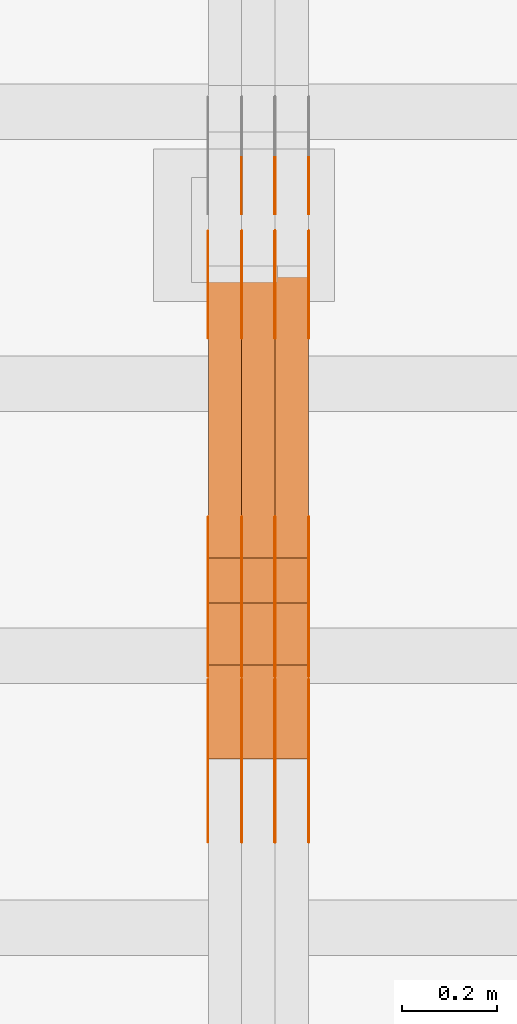
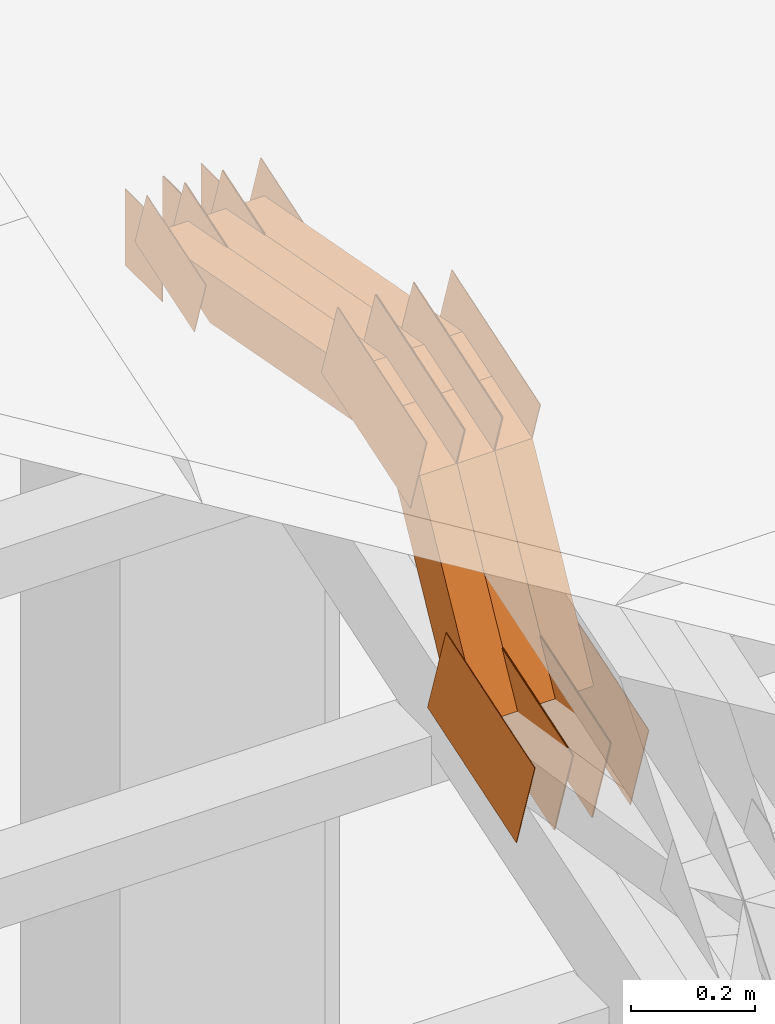
# One storey, part 277 of 385: 28 proxies.
"""IFC2X3 building model written with IfcOpenShell, lengths in millimetres."""

import ifcopenshell
import ifcopenshell.guid

model = None  # the IFC model being written
_history = None  # IfcOwnerHistory: only IFC2X3 demands one
_inside = {}  # id of a spatial element -> (the spatial element, [elements in it])
_under = {}  # id of a project, library or spatial element -> (it, [spatial elements below it])
_declared = {}  # id of a project -> (the project, [libraries it declares])
_typed = {}  # id of a type object -> (the type object, [elements of that type])
_made_of = {}  # id of a material, layer set ... -> (it, [elements and type objects made of it])


def new_model(schema):
    """Start an empty IFC model of exactly this schema.

    Asked for "IFC4X3", IfcOpenShell would pick the latest addendum, in which some entities
    have other attributes; the version numbers below select the first issue.
    IFC2X3 requires an IfcOwnerHistory on every rooted entity: one is made here for all.
    """
    global model, _history
    if schema == "IFC4X3":
        model = ifcopenshell.file(schema_version=(4, 3, 0, 0))
    else:
        model = ifcopenshell.file(schema=schema)
    _inside.clear()
    _under.clear()
    _declared.clear()
    _typed.clear()
    _made_of.clear()
    _history = None
    if model.schema == "IFC2X3":
        org = make("IfcOrganization", Name="unknown")
        user = make(
            "IfcPersonAndOrganization",
            ThePerson=make("IfcPerson", FamilyName="unknown"),
            TheOrganization=org,
        )
        app = make(
            "IfcApplication",
            ApplicationDeveloper=org,
            Version="unknown",
            ApplicationFullName="unknown",
            ApplicationIdentifier="unknown",
        )
        _history = make(
            "IfcOwnerHistory",
            OwningUser=user,
            OwningApplication=app,
            ChangeAction="ADDED",
            CreationDate=0,
        )
    return model


def make(cls, **values):
    """One entity of the class cls with the attributes given. An attribute that is None is left unset."""
    return model.create_entity(
        cls, **{name: value for name, value in values.items() if value is not None}
    )


def entity(cls, *values):
    """Any entity or typed value of the class cls, its attributes in the order of the schema. None: left unset."""
    e = model.create_entity(cls)
    for i, value in enumerate(values):
        if value is not None:
            e[i] = value
    return e


def rooted(cls, **values):
    """An entity with a GlobalId (a new one), such as an element, a storey or a relation."""
    return make(cls, GlobalId=ifcopenshell.guid.new(), OwnerHistory=_history, **values)


def si_unit(unit_type, name, prefix=None):
    """IfcSIUnit, for example si_unit("LENGTHUNIT", "METRE", prefix="MILLI")."""
    return make("IfcSIUnit", UnitType=unit_type, Prefix=prefix, Name=name)


def converted_unit(unit_type, name, factor, base, dimensions=None, offset=None):
    """IfcConversionBasedUnit, such as the inch: factor (a typed value) times the base unit."""
    return make(
        "IfcConversionBasedUnit"
        if offset is None
        else "IfcConversionBasedUnitWithOffset",
        ConversionOffset=offset,
        Dimensions=None
        if dimensions is None
        else entity("IfcDimensionalExponents", *dimensions),
        UnitType=unit_type,
        Name=name,
        ConversionFactor=make(
            "IfcMeasureWithUnit", ValueComponent=factor, UnitComponent=base
        ),
    )


def derived_unit(unit_type, elements):
    """IfcDerivedUnit: a product of units, each with its exponent."""
    return make(
        "IfcDerivedUnit",
        Elements=[
            make("IfcDerivedUnitElement", Unit=unit, Exponent=power)
            for unit, power in elements
        ],
        UnitType=unit_type,
    )


def assignment(units):
    """IfcUnitAssignment: the units of a project."""
    return None if units is None else make("IfcUnitAssignment", Units=units)


def point(xyz):
    """IfcCartesianPoint."""
    return None if xyz is None else make("IfcCartesianPoint", Coordinates=xyz)


def direction(xyz):
    """IfcDirection."""
    return None if xyz is None else make("IfcDirection", DirectionRatios=xyz)


def frame(location, z_axis=None, x_axis=None):
    """IfcAxis2Placement3D, a coordinate frame: its origin and axes. An axis left out is left unset."""
    return make(
        "IfcAxis2Placement3D",
        Location=point(location),
        Axis=direction(z_axis),
        RefDirection=direction(x_axis),
    )


def frame_2d(location, x_axis=None):
    """IfcAxis2Placement2D, a coordinate frame in the plane: its origin and x axis."""
    return make(
        "IfcAxis2Placement2D", Location=point(location), RefDirection=direction(x_axis)
    )


def origin():
    """The frame at (0, 0, 0) with its axes left unset."""
    return frame((0.0, 0.0, 0.0))


def place(relative_to, where):
    """IfcLocalPlacement: puts the frame where relative to a parent placement (None: the world)."""
    return make(
        "IfcLocalPlacement", PlacementRelTo=relative_to, RelativePlacement=where
    )


def context(
    kind, dimensions, precision=None, world=None, true_north=None, identifier=None
):
    """IfcGeometricRepresentationContext, for example the 3D "Model" context."""
    return make(
        "IfcGeometricRepresentationContext",
        ContextIdentifier=identifier,
        ContextType=kind,
        CoordinateSpaceDimension=dimensions,
        Precision=precision,
        WorldCoordinateSystem=world,
        TrueNorth=true_north,
    )


def subcontext(parent, identifier, kind, view, scale=None):
    """IfcGeometricRepresentationSubContext, for example "Body" below "Model"."""
    return make(
        "IfcGeometricRepresentationSubContext",
        ContextIdentifier=identifier,
        ContextType=kind,
        ParentContext=parent,
        TargetScale=scale,
        TargetView=view,
    )


def project(units=None, contexts=None):
    """IfcProject with its units and contexts."""
    return rooted(
        "IfcProject",
        Name="project",
        RepresentationContexts=contexts,
        UnitsInContext=assignment(units),
    )


def spatial(cls, under=None, at=None, **own):
    """A site, building, storey or space (cls), placed at a placement, below another one or the project."""
    s = rooted(cls, ObjectPlacement=at, **own)
    if under is not None:
        _under.setdefault(under.id(), (under, []))[1].append(s)
    return s


def polyline(points):
    """IfcPolyline through the points."""
    return make("IfcPolyline", Points=[point(p) for p in points])


def profile(cls, at=None, kind="AREA", **sizes):
    """A parametric profile (cls). Its sizes go by their IFC names, for example OverallWidth=200.0."""
    return make(cls, ProfileType=kind, Position=at, **sizes)


def rectangle(**sizes):
    """IfcRectangleProfileDef."""
    return profile("IfcRectangleProfileDef", **sizes)


def outline(outer, holes=None, kind="AREA"):
    """IfcArbitraryClosedProfileDef: a profile drawn as a closed curve; with holes, ...WithVoids."""
    if holes is None:
        return make("IfcArbitraryClosedProfileDef", ProfileType=kind, OuterCurve=outer)
    return make(
        "IfcArbitraryProfileDefWithVoids",
        ProfileType=kind,
        OuterCurve=outer,
        InnerCurves=holes,
    )


def extrude(swept, where, along, depth):
    """IfcExtrudedAreaSolid: the profile swept, set in the frame where, extruded along a direction by depth."""
    return make(
        "IfcExtrudedAreaSolid",
        SweptArea=swept,
        Position=where,
        ExtrudedDirection=direction(along),
        Depth=depth,
    )


def shape(context_of_items, identifier, shape_type, items):
    """IfcShapeRepresentation: the items that make up one representation, for example the "Body"."""
    return make(
        "IfcShapeRepresentation",
        ContextOfItems=context_of_items,
        RepresentationIdentifier=identifier,
        RepresentationType=shape_type,
        Items=items,
    )


def source(mapping_origin, context_of_items, identifier, shape_type, items):
    """IfcRepresentationMap: a shape defined once, which mapped items show again and again."""
    return make(
        "IfcRepresentationMap",
        MappingOrigin=mapping_origin,
        MappedRepresentation=shape(context_of_items, identifier, shape_type, items),
    )


def transform(
    local_origin,
    x_axis=None,
    y_axis=None,
    z_axis=None,
    scale=None,
    scale2=None,
    scale3=None,
    uniform=True,
):
    """IfcCartesianTransformationOperator3D, or its non-uniform kind. x_axis, y_axis, z_axis: its Axis1, 2, 3."""
    if uniform:
        return make(
            "IfcCartesianTransformationOperator3D",
            Axis1=direction(x_axis),
            Axis2=direction(y_axis),
            LocalOrigin=point(local_origin),
            Scale=scale,
            Axis3=direction(z_axis),
        )
    return make(
        "IfcCartesianTransformationOperator3DnonUniform",
        Axis1=direction(x_axis),
        Axis2=direction(y_axis),
        LocalOrigin=point(local_origin),
        Scale=scale,
        Axis3=direction(z_axis),
        Scale2=scale2,
        Scale3=scale3,
    )


def mapped(mapping_source, mapping_target):
    """IfcMappedItem: shows the shape of a source again, moved by a transform."""
    return make(
        "IfcMappedItem", MappingSource=mapping_source, MappingTarget=mapping_target
    )


def material(Name=None, Category=None):
    """IfcMaterial."""
    return make("IfcMaterial", Name=Name, Category=Category)


def made_of(thing, what):
    """Note that an element or type object is made of a material, layer set ...; save() writes the relation."""
    if what is not None:
        _made_of.setdefault(what.id(), (what, []))[1].append(thing)
    return thing


def type_object(cls, material=None, **own):
    """A type object (cls), such as IfcWallType, which elements share."""
    return made_of(rooted(cls, **own), material)


def type_shapes(of_type, sources):
    """Give a type object the sources (RepresentationMaps) that its elements show as mapped items."""
    of_type.RepresentationMaps = sources


def element(
    cls,
    number,
    at=None,
    inside=None,
    cuts=None,
    type_object=None,
    material=None,
    context=None,
    identifier="Body",
    shape_type=None,
    held_by="IfcProductDefinitionShape",
    body=None,
    shapes=None,
    **own,
):
    """One element of the class cls, such as IfcWall. Its Tag is "e" and its number.

    at: its placement. inside: the storey or other place that contains it. cuts: it is an
    opening in that element (IfcRelVoidsElement). A single representation is given by context,
    identifier, shape_type and body (its items); several are given by shapes. held_by: the class
    of the entity that holds the representations. save() writes the other relations.
    """
    e = rooted(cls, Tag="e%d" % number, ObjectPlacement=at, **own)
    if body is not None:
        shapes = [shape(context, identifier, shape_type, body)]
    if shapes is not None:
        e.Representation = make(held_by, Representations=shapes)
    if inside is not None:
        _inside.setdefault(inside.id(), (inside, []))[1].append(e)
    if cuts is not None:
        rooted(
            "IfcRelVoidsElement", RelatingBuildingElement=cuts, RelatedOpeningElement=e
        )
    if type_object is not None:
        _typed.setdefault(type_object.id(), (type_object, []))[1].append(e)
    return made_of(e, material)


def aggregate(whole, parts):
    """IfcRelAggregates: a whole, such as a stair, and the parts it consists of."""
    return rooted("IfcRelAggregates", RelatingObject=whole, RelatedObjects=parts)


def save(model, path):
    """Write the relations noted so far, then the file.

    IfcRelAggregates (storeys below a building ...), IfcRelContainedInSpatialStructure (elements
    in a storey), IfcRelDefinesByType, IfcRelAssociatesMaterial and IfcRelDeclares: one each for
    every whole, place, type object, material and project.
    """
    for whole, parts in _under.values():
        aggregate(whole, parts)
    for where, things in _inside.values():
        rooted(
            "IfcRelContainedInSpatialStructure",
            RelatedElements=things,
            RelatingStructure=where,
        )
    for kind, things in _typed.values():
        rooted("IfcRelDefinesByType", RelatedObjects=things, RelatingType=kind)
    for what, things in _made_of.values():
        rooted("IfcRelAssociatesMaterial", RelatedObjects=things, RelatingMaterial=what)
    for by, libraries in _declared.values():
        rooted("IfcRelDeclares", RelatingContext=by, RelatedDefinitions=libraries)
    model.write(path)


model = new_model("IFC2X3")

# Units and contexts
model_context = context("Model", 3, precision=0.01, world=origin(), true_north=direction((6.12303176911189e-17, 1.0)))
body_context = subcontext(model_context, "Body", "Model", "MODEL_VIEW")
ifc_project = project(units=[si_unit("LENGTHUNIT", "METRE", prefix="MILLI"), si_unit("AREAUNIT", "SQUARE_METRE"), si_unit("VOLUMEUNIT", "CUBIC_METRE"), converted_unit("PLANEANGLEUNIT", "DEGREE", entity("IfcRatioMeasure", 0.0174532925199433), si_unit("PLANEANGLEUNIT", "RADIAN"), dimensions=[0, 0, 0, 0, 0, 0, 0]), si_unit("MASSUNIT", "GRAM", prefix="KILO"), derived_unit("MASSDENSITYUNIT", [(si_unit("MASSUNIT", "GRAM", prefix="KILO"), 1), (si_unit("LENGTHUNIT", "METRE"), -3)]), si_unit("TIMEUNIT", "SECOND"), si_unit("FREQUENCYUNIT", "HERTZ"), si_unit("THERMODYNAMICTEMPERATUREUNIT", "DEGREE_CELSIUS"), derived_unit("THERMALTRANSMITTANCEUNIT", [(si_unit("MASSUNIT", "GRAM", prefix="KILO"), 1), (si_unit("THERMODYNAMICTEMPERATUREUNIT", "KELVIN"), -1), (si_unit("TIMEUNIT", "SECOND"), -3)]), derived_unit("VOLUMETRICFLOWRATEUNIT", [(si_unit("LENGTHUNIT", "METRE"), 3), (si_unit("TIMEUNIT", "SECOND"), -1)]), si_unit("ELECTRICCURRENTUNIT", "AMPERE"), si_unit("ELECTRICVOLTAGEUNIT", "VOLT"), si_unit("POWERUNIT", "WATT"), si_unit("FORCEUNIT", "NEWTON", prefix="KILO"), si_unit("ILLUMINANCEUNIT", "LUX"), si_unit("LUMINOUSFLUXUNIT", "LUMEN"), si_unit("LUMINOUSINTENSITYUNIT", "CANDELA"), derived_unit("USERDEFINED", [(si_unit("MASSUNIT", "GRAM", prefix="KILO"), -1), (si_unit("LENGTHUNIT", "METRE"), -2), (si_unit("TIMEUNIT", "SECOND"), 3), (si_unit("LUMINOUSFLUXUNIT", "LUMEN"), 1)]), derived_unit("LINEARVELOCITYUNIT", [(si_unit("LENGTHUNIT", "METRE"), 1), (si_unit("TIMEUNIT", "SECOND"), -1)]), si_unit("PRESSUREUNIT", "PASCAL"), derived_unit("USERDEFINED", [(si_unit("LENGTHUNIT", "METRE"), -2), (si_unit("MASSUNIT", "GRAM", prefix="KILO"), 1), (si_unit("TIMEUNIT", "SECOND"), -2)])], contexts=[model_context])

# Site, building, storey
site_placement = place(None, origin())
site = spatial("IfcSite", under=ifc_project, at=site_placement, CompositionType="ELEMENT")
building_placement = place(site_placement, origin())
building = spatial("IfcBuilding", under=site, at=building_placement, CompositionType="ELEMENT")
storey_placement = place(building_placement, origin())
storey = spatial("IfcBuildingStorey", under=building, at=storey_placement, Name="Default", CompositionType="ELEMENT", Elevation=0.0)

# Proxies
ifc_material_1 = material(Name="IfcSurfaceStyle #415048")
building_element_proxy_type_1 = type_object("IfcBuildingElementProxyType", PredefinedType="NOTDEFINED", material=ifc_material_1)
shared_shape_1 = source(origin(), body_context, "Body", "SweptSolid", [
    extrude(outline(polyline([(-149.99966632326, -95.9999759039407), (149.999881095801, -95.9999759039407), (150.000557367591, 95.9999759039407), (-150.000772140132, 95.9999759039406), (-149.99966632326, -95.9999759039407)])), frame((150.000557367591, 96.0004291135906, 0.0), z_axis=(0.0, 0.0, 1.0), x_axis=(-1.0, 0.0, 0.0)), (0.0, 0.0, 1.0), 1.29999999999999),
])
type_shapes(building_element_proxy_type_1, [shared_shape_1])
proxy_1_placement = place(building_placement, frame((33386.3, 10934.7734375, 2766.8759765625), z_axis=(-1.0, 0.0, 0.0), x_axis=(0.0, 0.951056516295124, 0.309016994375039)))
element("IfcBuildingElementProxy", 1, at=proxy_1_placement, inside=storey, type_object=building_element_proxy_type_1, material=ifc_material_1, context=body_context, shape_type="MappedRepresentation", body=[
    mapped(shared_shape_1, transform((0.0, 0.0, 0.0), scale=1.0)),
])
ifc_material_2 = material(Name="IfcSurfaceStyle #414991")
building_element_proxy_type_2 = type_object("IfcBuildingElementProxyType", PredefinedType="NOTDEFINED", material=ifc_material_2)
shared_shape_2 = source(origin(), body_context, "Body", "SweptSolid", [
    extrude(outline(polyline([(-149.99966632326, -95.9999759039407), (149.999881095801, -95.9999759039407), (150.000557367591, 95.9999759039407), (-150.000772140132, 95.9999759039406), (-149.99966632326, -95.9999759039407)])), frame((150.000557367591, 96.0004291135906, 0.0), z_axis=(0.0, 0.0, 1.0), x_axis=(-1.0, 0.0, 0.0)), (0.0, 0.0, 1.0), 1.29999999999999),
])
type_shapes(building_element_proxy_type_2, [shared_shape_2])
proxy_2_placement = place(building_placement, frame((33315.0, 10934.7734375, 2766.8759765625), z_axis=(-1.0, 0.0, 0.0), x_axis=(0.0, 0.951056516295124, 0.309016994375039)))
element("IfcBuildingElementProxy", 2, at=proxy_2_placement, inside=storey, type_object=building_element_proxy_type_2, material=ifc_material_2, context=body_context, shape_type="MappedRepresentation", body=[
    mapped(shared_shape_2, transform((0.0, 0.0, 0.0), scale=1.0)),
])
ifc_material_3 = material(Name="IfcSurfaceStyle #414934")
building_element_proxy_type_3 = type_object("IfcBuildingElementProxyType", PredefinedType="NOTDEFINED", material=ifc_material_3)
shared_shape_3 = source(origin(), body_context, "Body", "SweptSolid", [
    extrude(outline(polyline([(-149.99966632326, -95.9999759039407), (149.999881095801, -95.9999759039407), (150.000557367591, 95.9999759039407), (-150.000772140132, 95.9999759039406), (-149.99966632326, -95.9999759039407)])), frame((150.000557367591, 96.0004291135906, 0.0), z_axis=(0.0, 0.0, 1.0), x_axis=(-1.0, 0.0, 0.0)), (0.0, 0.0, 1.0), 1.29999999999999),
])
type_shapes(building_element_proxy_type_3, [shared_shape_3])
proxy_3_placement = place(building_placement, frame((33316.3, 10934.7734375, 2766.8759765625), z_axis=(-1.0, 0.0, 0.0), x_axis=(0.0, 0.951056516295124, 0.309016994375039)))
element("IfcBuildingElementProxy", 3, at=proxy_3_placement, inside=storey, type_object=building_element_proxy_type_3, material=ifc_material_3, context=body_context, shape_type="MappedRepresentation", body=[
    mapped(shared_shape_3, transform((0.0, 0.0, 0.0), scale=1.0)),
])
ifc_material_4 = material(Name="IfcSurfaceStyle #414877")
building_element_proxy_type_4 = type_object("IfcBuildingElementProxyType", PredefinedType="NOTDEFINED", material=ifc_material_4)
shared_shape_4 = source(origin(), body_context, "Body", "SweptSolid", [
    extrude(outline(polyline([(-149.99966632326, -95.9999759039407), (149.999881095801, -95.9999759039407), (150.000557367591, 95.9999759039407), (-150.000772140132, 95.9999759039406), (-149.99966632326, -95.9999759039407)])), frame((150.000557367591, 96.0004291135906, 0.0), z_axis=(0.0, 0.0, 1.0), x_axis=(-1.0, 0.0, 0.0)), (0.0, 0.0, 1.0), 1.29999999999998),
])
type_shapes(building_element_proxy_type_4, [shared_shape_4])
proxy_4_placement = place(building_placement, frame((33245.0, 10934.7734375, 2766.8759765625), z_axis=(-1.0, 0.0, 0.0), x_axis=(0.0, 0.951056516295124, 0.309016994375039)))
element("IfcBuildingElementProxy", 4, at=proxy_4_placement, inside=storey, type_object=building_element_proxy_type_4, material=ifc_material_4, context=body_context, shape_type="MappedRepresentation", body=[
    mapped(shared_shape_4, transform((0.0, 0.0, 0.0), scale=1.0)),
])
ifc_material_5 = material(Name="IfcSurfaceStyle #414820")
building_element_proxy_type_5 = type_object("IfcBuildingElementProxyType", PredefinedType="NOTDEFINED", material=ifc_material_5)
shared_shape_5 = source(origin(), body_context, "Body", "SweptSolid", [
    extrude(outline(polyline([(-149.99966632326, -95.9999759039407), (149.999881095801, -95.9999759039407), (150.000557367591, 95.9999759039407), (-150.000772140132, 95.9999759039406), (-149.99966632326, -95.9999759039407)])), frame((150.000557367591, 96.0004291135906, 0.0), z_axis=(0.0, 0.0, 1.0), x_axis=(-1.0, 0.0, 0.0)), (0.0, 0.0, 1.0), 1.29999999999998),
])
type_shapes(building_element_proxy_type_5, [shared_shape_5])
proxy_5_placement = place(building_placement, frame((33246.3, 10934.7734375, 2766.8759765625), z_axis=(-1.0, 0.0, 0.0), x_axis=(0.0, 0.951056516295124, 0.309016994375039)))
element("IfcBuildingElementProxy", 5, at=proxy_5_placement, inside=storey, type_object=building_element_proxy_type_5, material=ifc_material_5, context=body_context, shape_type="MappedRepresentation", body=[
    mapped(shared_shape_5, transform((0.0, 0.0, 0.0), scale=1.0)),
])
ifc_material_6 = material(Name="IfcSurfaceStyle #414763")
building_element_proxy_type_6 = type_object("IfcBuildingElementProxyType", PredefinedType="NOTDEFINED", material=ifc_material_6)
shared_shape_6 = source(origin(), body_context, "Body", "SweptSolid", [
    extrude(outline(polyline([(-149.99966632326, -95.9999759039407), (149.999881095801, -95.9999759039407), (150.000557367591, 95.9999759039407), (-150.000772140132, 95.9999759039406), (-149.99966632326, -95.9999759039407)])), frame((150.000557367591, 96.0004291135906, 0.0), z_axis=(0.0, 0.0, 1.0), x_axis=(-1.0, 0.0, 0.0)), (0.0, 0.0, 1.0), 1.29999999999998),
])
type_shapes(building_element_proxy_type_6, [shared_shape_6])
proxy_6_placement = place(building_placement, frame((33175.0, 10934.7734375, 2766.8759765625), z_axis=(-1.0, 0.0, 0.0), x_axis=(0.0, 0.951056516295124, 0.309016994375039)))
element("IfcBuildingElementProxy", 6, at=proxy_6_placement, inside=storey, type_object=building_element_proxy_type_6, material=ifc_material_6, context=body_context, shape_type="MappedRepresentation", body=[
    mapped(shared_shape_6, transform((0.0, 0.0, 0.0), scale=1.0)),
])
ifc_material_7 = material(Name="IfcSurfaceStyle #413680")
building_element_proxy_type_7 = type_object("IfcBuildingElementProxyType", PredefinedType="NOTDEFINED", material=ifc_material_7)
shared_shape_7 = source(origin(), body_context, "Body", "SweptSolid", [
    extrude(outline(polyline([(-99.9997874178038, -60.0000528641967), (99.9998102700997, -60.0000528641967), (99.9998251396068, 60.0000528641967), (-99.9998479919027, 60.0000528641967), (-99.9997874178038, -60.0000528641967)])), frame((99.9999918898597, 60.0000528641967, 0.0), z_axis=(0.0, 0.0, 1.0), x_axis=(-1.0, 0.0, 0.0)), (0.0, 0.0, 1.0), 1.3),
])
type_shapes(building_element_proxy_type_7, [shared_shape_7])
proxy_7_placement = place(building_placement, frame((33386.3, 11991.9568177725, 3072.52282247925), z_axis=(-1.0, 0.0, 0.0), x_axis=(0.0, 0.951056516295124, 0.309016994375039)))
element("IfcBuildingElementProxy", 7, at=proxy_7_placement, inside=storey, type_object=building_element_proxy_type_7, material=ifc_material_7, context=body_context, shape_type="MappedRepresentation", body=[
    mapped(shared_shape_7, transform((0.0, 0.0, 0.0), scale=1.0)),
])
ifc_material_8 = material(Name="IfcSurfaceStyle #413623")
building_element_proxy_type_8 = type_object("IfcBuildingElementProxyType", PredefinedType="NOTDEFINED", material=ifc_material_8)
shared_shape_8 = source(origin(), body_context, "Body", "SweptSolid", [
    extrude(outline(polyline([(-99.9997874178038, -60.0000528641967), (99.9998102700997, -60.0000528641967), (99.9998251396068, 60.0000528641967), (-99.9998479919027, 60.0000528641967), (-99.9997874178038, -60.0000528641967)])), frame((99.9999918898597, 60.0000528641967, 0.0), z_axis=(0.0, 0.0, 1.0), x_axis=(-1.0, 0.0, 0.0)), (0.0, 0.0, 1.0), 1.3),
])
type_shapes(building_element_proxy_type_8, [shared_shape_8])
proxy_8_placement = place(building_placement, frame((33315.0, 11991.9568177725, 3072.52282247925), z_axis=(-1.0, 0.0, 0.0), x_axis=(0.0, 0.951056516295124, 0.309016994375039)))
element("IfcBuildingElementProxy", 8, at=proxy_8_placement, inside=storey, type_object=building_element_proxy_type_8, material=ifc_material_8, context=body_context, shape_type="MappedRepresentation", body=[
    mapped(shared_shape_8, transform((0.0, 0.0, 0.0), scale=1.0)),
])
ifc_material_9 = material(Name="IfcSurfaceStyle #413566")
building_element_proxy_type_9 = type_object("IfcBuildingElementProxyType", PredefinedType="NOTDEFINED", material=ifc_material_9)
shared_shape_9 = source(origin(), body_context, "Body", "SweptSolid", [
    extrude(outline(polyline([(-99.9997874178038, -60.0000528641967), (99.9998102700997, -60.0000528641967), (99.9998251396068, 60.0000528641967), (-99.9998479919027, 60.0000528641967), (-99.9997874178038, -60.0000528641967)])), frame((99.9999918898597, 60.0000528641967, 0.0), z_axis=(0.0, 0.0, 1.0), x_axis=(-1.0, 0.0, 0.0)), (0.0, 0.0, 1.0), 1.3),
])
type_shapes(building_element_proxy_type_9, [shared_shape_9])
proxy_9_placement = place(building_placement, frame((33316.3, 11991.9568177725, 3072.52282247925), z_axis=(-1.0, 0.0, 0.0), x_axis=(0.0, 0.951056516295124, 0.309016994375039)))
element("IfcBuildingElementProxy", 9, at=proxy_9_placement, inside=storey, type_object=building_element_proxy_type_9, material=ifc_material_9, context=body_context, shape_type="MappedRepresentation", body=[
    mapped(shared_shape_9, transform((0.0, 0.0, 0.0), scale=1.0)),
])
ifc_material_10 = material(Name="IfcSurfaceStyle #413509")
building_element_proxy_type_10 = type_object("IfcBuildingElementProxyType", PredefinedType="NOTDEFINED", material=ifc_material_10)
shared_shape_10 = source(origin(), body_context, "Body", "SweptSolid", [
    extrude(outline(polyline([(-99.9997874178038, -60.0000528641967), (99.9998102700997, -60.0000528641967), (99.9998251396068, 60.0000528641967), (-99.9998479919027, 60.0000528641967), (-99.9997874178038, -60.0000528641967)])), frame((99.9999918898597, 60.0000528641967, 0.0), z_axis=(0.0, 0.0, 1.0), x_axis=(-1.0, 0.0, 0.0)), (0.0, 0.0, 1.0), 1.29999999999998),
])
type_shapes(building_element_proxy_type_10, [shared_shape_10])
proxy_10_placement = place(building_placement, frame((33245.0, 11991.9568177725, 3072.52282247925), z_axis=(-1.0, 0.0, 0.0), x_axis=(0.0, 0.951056516295124, 0.309016994375039)))
element("IfcBuildingElementProxy", 10, at=proxy_10_placement, inside=storey, type_object=building_element_proxy_type_10, material=ifc_material_10, context=body_context, shape_type="MappedRepresentation", body=[
    mapped(shared_shape_10, transform((0.0, 0.0, 0.0), scale=1.0)),
])
ifc_material_11 = material(Name="IfcSurfaceStyle #413452")
building_element_proxy_type_11 = type_object("IfcBuildingElementProxyType", PredefinedType="NOTDEFINED", material=ifc_material_11)
shared_shape_11 = source(origin(), body_context, "Body", "SweptSolid", [
    extrude(outline(polyline([(-99.9997874178038, -60.0000528641967), (99.9998102700997, -60.0000528641967), (99.9998251396068, 60.0000528641967), (-99.9998479919027, 60.0000528641967), (-99.9997874178038, -60.0000528641967)])), frame((99.9999918898597, 60.0000528641967, 0.0), z_axis=(0.0, 0.0, 1.0), x_axis=(-1.0, 0.0, 0.0)), (0.0, 0.0, 1.0), 1.29999999999998),
])
type_shapes(building_element_proxy_type_11, [shared_shape_11])
proxy_11_placement = place(building_placement, frame((33246.3, 11991.9568177725, 3072.52282247925), z_axis=(-1.0, 0.0, 0.0), x_axis=(0.0, 0.951056516295124, 0.309016994375039)))
element("IfcBuildingElementProxy", 11, at=proxy_11_placement, inside=storey, type_object=building_element_proxy_type_11, material=ifc_material_11, context=body_context, shape_type="MappedRepresentation", body=[
    mapped(shared_shape_11, transform((0.0, 0.0, 0.0), scale=1.0)),
])
ifc_material_12 = material(Name="IfcSurfaceStyle #413395")
building_element_proxy_type_12 = type_object("IfcBuildingElementProxyType", PredefinedType="NOTDEFINED", material=ifc_material_12)
shared_shape_12 = source(origin(), body_context, "Body", "SweptSolid", [
    extrude(outline(polyline([(-99.9997874178038, -60.0000528641967), (99.9998102700997, -60.0000528641967), (99.9998251396068, 60.0000528641967), (-99.9998479919027, 60.0000528641967), (-99.9997874178038, -60.0000528641967)])), frame((99.9999918898597, 60.0000528641967, 0.0), z_axis=(0.0, 0.0, 1.0), x_axis=(-1.0, 0.0, 0.0)), (0.0, 0.0, 1.0), 1.29999999999999),
])
type_shapes(building_element_proxy_type_12, [shared_shape_12])
proxy_12_placement = place(building_placement, frame((33175.0, 11991.9568177725, 3072.52282247925), z_axis=(-1.0, 0.0, 0.0), x_axis=(0.0, 0.951056516295124, 0.309016994375039)))
element("IfcBuildingElementProxy", 12, at=proxy_12_placement, inside=storey, type_object=building_element_proxy_type_12, material=ifc_material_12, context=body_context, shape_type="MappedRepresentation", body=[
    mapped(shared_shape_12, transform((0.0, 0.0, 0.0), scale=1.0)),
])
ifc_material_13 = material(Name="IfcSurfaceStyle #413338")
building_element_proxy_type_13 = type_object("IfcBuildingElementProxyType", PredefinedType="NOTDEFINED", material=ifc_material_13)
shared_shape_13 = source(origin(), body_context, "Body", "SweptSolid", [
    extrude(rectangle(XDim=150.0, YDim=119.999999999985, at=frame_2d((-7.105427357601e-15, 0.0), x_axis=(1.0, 0.0))), frame((75.0, 60.0, 0.0), z_axis=(0.0, 0.0, 1.0), x_axis=(-1.0, 0.0, 0.0)), (0.0, 0.0, 1.0), 1.3),
])
type_shapes(building_element_proxy_type_13, [shared_shape_13])
proxy_13_placement = place(building_placement, frame((33386.3, 12372.95703125, 3007.04687500001), z_axis=(-1.0, 0.0, 0.0), x_axis=(0.0, 0.0, -1.0)))
element("IfcBuildingElementProxy", 13, at=proxy_13_placement, inside=storey, type_object=building_element_proxy_type_13, material=ifc_material_13, context=body_context, shape_type="MappedRepresentation", body=[
    mapped(shared_shape_13, transform((0.0, 0.0, 0.0), scale=1.0)),
])
ifc_material_14 = material(Name="IfcSurfaceStyle #413281")
building_element_proxy_type_14 = type_object("IfcBuildingElementProxyType", PredefinedType="NOTDEFINED", material=ifc_material_14)
shared_shape_14 = source(origin(), body_context, "Body", "SweptSolid", [
    extrude(rectangle(XDim=150.0, YDim=119.999999999985, at=frame_2d((-7.105427357601e-15, 0.0), x_axis=(1.0, 0.0))), frame((75.0, 60.0, 0.0), z_axis=(0.0, 0.0, 1.0), x_axis=(-1.0, 0.0, 0.0)), (0.0, 0.0, 1.0), 1.3),
])
type_shapes(building_element_proxy_type_14, [shared_shape_14])
proxy_14_placement = place(building_placement, frame((33315.0, 12372.95703125, 3007.04687500001), z_axis=(-1.0, 0.0, 0.0), x_axis=(0.0, 0.0, -1.0)))
element("IfcBuildingElementProxy", 14, at=proxy_14_placement, inside=storey, type_object=building_element_proxy_type_14, material=ifc_material_14, context=body_context, shape_type="MappedRepresentation", body=[
    mapped(shared_shape_14, transform((0.0, 0.0, 0.0), scale=1.0)),
])
ifc_material_15 = material(Name="IfcSurfaceStyle #413224")
building_element_proxy_type_15 = type_object("IfcBuildingElementProxyType", PredefinedType="NOTDEFINED", material=ifc_material_15)
shared_shape_15 = source(origin(), body_context, "Body", "SweptSolid", [
    extrude(rectangle(XDim=150.0, YDim=119.999999999985, at=frame_2d((-7.105427357601e-15, 0.0), x_axis=(1.0, 0.0))), frame((75.0, 60.0, 0.0), z_axis=(0.0, 0.0, 1.0), x_axis=(-1.0, 0.0, 0.0)), (0.0, 0.0, 1.0), 1.3),
])
type_shapes(building_element_proxy_type_15, [shared_shape_15])
proxy_15_placement = place(building_placement, frame((33316.3, 12372.95703125, 3007.04687500001), z_axis=(-1.0, 0.0, 0.0), x_axis=(0.0, 0.0, -1.0)))
element("IfcBuildingElementProxy", 15, at=proxy_15_placement, inside=storey, type_object=building_element_proxy_type_15, material=ifc_material_15, context=body_context, shape_type="MappedRepresentation", body=[
    mapped(shared_shape_15, transform((0.0, 0.0, 0.0), scale=1.0)),
])
ifc_material_16 = material(Name="IfcSurfaceStyle #413167")
building_element_proxy_type_16 = type_object("IfcBuildingElementProxyType", PredefinedType="NOTDEFINED", material=ifc_material_16)
shared_shape_16 = source(origin(), body_context, "Body", "SweptSolid", [
    extrude(rectangle(XDim=150.0, YDim=119.999999999985, at=frame_2d((-7.105427357601e-15, 0.0), x_axis=(1.0, 0.0))), frame((75.0, 60.0, 0.0), z_axis=(0.0, 0.0, 1.0), x_axis=(-1.0, 0.0, 0.0)), (0.0, 0.0, 1.0), 1.29999999999999),
])
type_shapes(building_element_proxy_type_16, [shared_shape_16])
proxy_16_placement = place(building_placement, frame((33245.0, 12372.95703125, 3007.04687500001), z_axis=(-1.0, 0.0, 0.0), x_axis=(0.0, 0.0, -1.0)))
element("IfcBuildingElementProxy", 16, at=proxy_16_placement, inside=storey, type_object=building_element_proxy_type_16, material=ifc_material_16, context=body_context, shape_type="MappedRepresentation", body=[
    mapped(shared_shape_16, transform((0.0, 0.0, 0.0), scale=1.0)),
])
ifc_material_17 = material(Name="IfcSurfaceStyle #405472")
building_element_proxy_type_17 = type_object("IfcBuildingElementProxyType", PredefinedType="NOTDEFINED", material=ifc_material_17)
shared_shape_17 = source(origin(), body_context, "Body", "SweptSolid", [
    extrude(outline(polyline([(-150.000273478628, -84.0002987844282), (149.999198496832, -84.0002987844282), (150.000273478627, 84.0002987844282), (-149.999198496831, 84.0002987844282), (-150.000273478628, -84.0002987844282)])), frame((150.000273478627, 84.0002987844282, 0.0), z_axis=(0.0, 0.0, 1.0), x_axis=(-1.0, 0.0, 0.0)), (0.0, 0.0, 1.0), 1.29999999999999),
])
type_shapes(building_element_proxy_type_17, [shared_shape_17])
proxy_17_placement = place(building_placement, frame((33386.3, 11283.0116722926, 3194.09682266857), z_axis=(-1.0, 0.0, 0.0), x_axis=(0.0, 0.951056516295154, 0.309016994374948)))
element("IfcBuildingElementProxy", 17, at=proxy_17_placement, inside=storey, type_object=building_element_proxy_type_17, material=ifc_material_17, context=body_context, shape_type="MappedRepresentation", body=[
    mapped(shared_shape_17, transform((0.0, 0.0, 0.0), scale=1.0)),
])
ifc_material_18 = material(Name="IfcSurfaceStyle #405415")
building_element_proxy_type_18 = type_object("IfcBuildingElementProxyType", PredefinedType="NOTDEFINED", material=ifc_material_18)
shared_shape_18 = source(origin(), body_context, "Body", "SweptSolid", [
    extrude(outline(polyline([(-150.000273478628, -84.0002987844282), (149.999198496832, -84.0002987844282), (150.000273478627, 84.0002987844282), (-149.999198496831, 84.0002987844282), (-150.000273478628, -84.0002987844282)])), frame((150.000273478627, 84.0002987844282, 0.0), z_axis=(0.0, 0.0, 1.0), x_axis=(-1.0, 0.0, 0.0)), (0.0, 0.0, 1.0), 1.29999999999999),
])
type_shapes(building_element_proxy_type_18, [shared_shape_18])
proxy_18_placement = place(building_placement, frame((33315.0, 11283.0116722926, 3194.09682266857), z_axis=(-1.0, 0.0, 0.0), x_axis=(0.0, 0.951056516295154, 0.309016994374948)))
element("IfcBuildingElementProxy", 18, at=proxy_18_placement, inside=storey, type_object=building_element_proxy_type_18, material=ifc_material_18, context=body_context, shape_type="MappedRepresentation", body=[
    mapped(shared_shape_18, transform((0.0, 0.0, 0.0), scale=1.0)),
])
ifc_material_19 = material(Name="IfcSurfaceStyle #405358")
building_element_proxy_type_19 = type_object("IfcBuildingElementProxyType", PredefinedType="NOTDEFINED", material=ifc_material_19)
shared_shape_19 = source(origin(), body_context, "Body", "SweptSolid", [
    extrude(outline(polyline([(-150.000273478628, -84.0002987844282), (149.999198496832, -84.0002987844282), (150.000273478627, 84.0002987844282), (-149.999198496831, 84.0002987844282), (-150.000273478628, -84.0002987844282)])), frame((150.000273478627, 84.0002987844282, 0.0), z_axis=(0.0, 0.0, 1.0), x_axis=(-1.0, 0.0, 0.0)), (0.0, 0.0, 1.0), 1.29999999999999),
])
type_shapes(building_element_proxy_type_19, [shared_shape_19])
proxy_19_placement = place(building_placement, frame((33316.3, 11283.0116722926, 3194.09682266857), z_axis=(-1.0, 0.0, 0.0), x_axis=(0.0, 0.951056516295154, 0.309016994374948)))
element("IfcBuildingElementProxy", 19, at=proxy_19_placement, inside=storey, type_object=building_element_proxy_type_19, material=ifc_material_19, context=body_context, shape_type="MappedRepresentation", body=[
    mapped(shared_shape_19, transform((0.0, 0.0, 0.0), scale=1.0)),
])
ifc_material_20 = material(Name="IfcSurfaceStyle #405301")
building_element_proxy_type_20 = type_object("IfcBuildingElementProxyType", PredefinedType="NOTDEFINED", material=ifc_material_20)
shared_shape_20 = source(origin(), body_context, "Body", "SweptSolid", [
    extrude(outline(polyline([(-150.000273478628, -84.0002987844282), (149.999198496832, -84.0002987844282), (150.000273478627, 84.0002987844282), (-149.999198496831, 84.0002987844282), (-150.000273478628, -84.0002987844282)])), frame((150.000273478627, 84.0002987844282, 0.0), z_axis=(0.0, 0.0, 1.0), x_axis=(-1.0, 0.0, 0.0)), (0.0, 0.0, 1.0), 1.29999999999998),
])
type_shapes(building_element_proxy_type_20, [shared_shape_20])
proxy_20_placement = place(building_placement, frame((33245.0, 11283.0116722926, 3194.09682266857), z_axis=(-1.0, 0.0, 0.0), x_axis=(0.0, 0.951056516295154, 0.309016994374948)))
element("IfcBuildingElementProxy", 20, at=proxy_20_placement, inside=storey, type_object=building_element_proxy_type_20, material=ifc_material_20, context=body_context, shape_type="MappedRepresentation", body=[
    mapped(shared_shape_20, transform((0.0, 0.0, 0.0), scale=1.0)),
])
ifc_material_21 = material(Name="IfcSurfaceStyle #405244")
building_element_proxy_type_21 = type_object("IfcBuildingElementProxyType", PredefinedType="NOTDEFINED", material=ifc_material_21)
shared_shape_21 = source(origin(), body_context, "Body", "SweptSolid", [
    extrude(outline(polyline([(-150.000273478628, -84.0002987844282), (149.999198496832, -84.0002987844282), (150.000273478627, 84.0002987844282), (-149.999198496831, 84.0002987844282), (-150.000273478628, -84.0002987844282)])), frame((150.000273478627, 84.0002987844282, 0.0), z_axis=(0.0, 0.0, 1.0), x_axis=(-1.0, 0.0, 0.0)), (0.0, 0.0, 1.0), 1.29999999999998),
])
type_shapes(building_element_proxy_type_21, [shared_shape_21])
proxy_21_placement = place(building_placement, frame((33246.3, 11283.0116722926, 3194.09682266857), z_axis=(-1.0, 0.0, 0.0), x_axis=(0.0, 0.951056516295154, 0.309016994374948)))
element("IfcBuildingElementProxy", 21, at=proxy_21_placement, inside=storey, type_object=building_element_proxy_type_21, material=ifc_material_21, context=body_context, shape_type="MappedRepresentation", body=[
    mapped(shared_shape_21, transform((0.0, 0.0, 0.0), scale=1.0)),
])
ifc_material_22 = material(Name="IfcSurfaceStyle #405187")
building_element_proxy_type_22 = type_object("IfcBuildingElementProxyType", PredefinedType="NOTDEFINED", material=ifc_material_22)
shared_shape_22 = source(origin(), body_context, "Body", "SweptSolid", [
    extrude(outline(polyline([(-150.000273478628, -84.0002987844282), (149.999198496832, -84.0002987844282), (150.000273478627, 84.0002987844282), (-149.999198496831, 84.0002987844282), (-150.000273478628, -84.0002987844282)])), frame((150.000273478627, 84.0002987844282, 0.0), z_axis=(0.0, 0.0, 1.0), x_axis=(-1.0, 0.0, 0.0)), (0.0, 0.0, 1.0), 1.29999999999998),
])
type_shapes(building_element_proxy_type_22, [shared_shape_22])
proxy_22_placement = place(building_placement, frame((33175.0, 11283.0116722926, 3194.09682266857), z_axis=(-1.0, 0.0, 0.0), x_axis=(0.0, 0.951056516295154, 0.309016994374948)))
element("IfcBuildingElementProxy", 22, at=proxy_22_placement, inside=storey, type_object=building_element_proxy_type_22, material=ifc_material_22, context=body_context, shape_type="MappedRepresentation", body=[
    mapped(shared_shape_22, transform((0.0, 0.0, 0.0), scale=1.0)),
])
ifc_material_23 = material(Name="IfcSurfaceStyle #395176")
building_element_proxy_type_23 = type_object("IfcBuildingElementProxyType", Name="T1-W9 395174", PredefinedType="NOTDEFINED", material=ifc_material_23)
shared_shape_23 = source(origin(), body_context, "Body", "SweptSolid", [
    extrude(outline(polyline([(-287.457507623288, -47.5000268597988), (288.590479960635, -47.5000268597988), (273.55062971372, -2.33146189358546e-05), (186.625054999886, 47.5000385171083), (-461.308657050953, 47.5000385171083), (-287.457507623288, -47.5000268597988)])), frame((288.590945855618, 47.5000968036551, 0.0), z_axis=(0.0, 0.0, 1.0), x_axis=(-1.0, 0.0, 0.0)), (0.0, 0.0, 1.0), 70.0),
])
type_shapes(building_element_proxy_type_23, [shared_shape_23])
proxy_23_placement = place(building_placement, frame((33385.0, 11432.1200855376, 3205.63308612017), z_axis=(-1.0, 0.0, 0.0), x_axis=(0.0, 0.982760503514031, -0.184883186722992)))
element("IfcBuildingElementProxy", 23, at=proxy_23_placement, inside=storey, type_object=building_element_proxy_type_23, material=ifc_material_23, Name="T1-W9", context=body_context, shape_type="MappedRepresentation", body=[
    mapped(shared_shape_23, transform((0.0, 0.0, 0.0), scale=1.0)),
])
ifc_material_24 = material(Name="IfcSurfaceStyle #395110")
building_element_proxy_type_24 = type_object("IfcBuildingElementProxyType", Name="T1-W9 395108", PredefinedType="NOTDEFINED", material=ifc_material_24)
shared_shape_24 = source(origin(), body_context, "Body", "SweptSolid", [
    extrude(outline(polyline([(-287.457507623288, -47.5000268597988), (288.590479960635, -47.5000268597988), (273.55062971372, -2.33146189358546e-05), (186.625054999886, 47.5000385171083), (-461.308657050953, 47.5000385171083), (-287.457507623288, -47.5000268597988)])), frame((288.590945855618, 47.5000968036551, 0.0), z_axis=(0.0, 0.0, 1.0), x_axis=(-1.0, 0.0, 0.0)), (0.0, 0.0, 1.0), 70.0),
])
type_shapes(building_element_proxy_type_24, [shared_shape_24])
proxy_24_placement = place(building_placement, frame((33315.0, 11432.1200855376, 3205.63308612017), z_axis=(-1.0, 0.0, 0.0), x_axis=(0.0, 0.982760503514031, -0.184883186722992)))
element("IfcBuildingElementProxy", 24, at=proxy_24_placement, inside=storey, type_object=building_element_proxy_type_24, material=ifc_material_24, Name="T1-W9", context=body_context, shape_type="MappedRepresentation", body=[
    mapped(shared_shape_24, transform((0.0, 0.0, 0.0), scale=1.0)),
])
ifc_material_25 = material(Name="IfcSurfaceStyle #395044")
building_element_proxy_type_25 = type_object("IfcBuildingElementProxyType", Name="T1-W9 395042", PredefinedType="NOTDEFINED", material=ifc_material_25)
shared_shape_25 = source(origin(), body_context, "Body", "SweptSolid", [
    extrude(outline(polyline([(-287.457507623288, -47.5000268597988), (288.590479960635, -47.5000268597988), (273.55062971372, -2.33146189358546e-05), (186.625054999886, 47.5000385171083), (-461.308657050953, 47.5000385171083), (-287.457507623288, -47.5000268597988)])), frame((288.590945855618, 47.5000968036551, 0.0), z_axis=(0.0, 0.0, 1.0), x_axis=(-1.0, 0.0, 0.0)), (0.0, 0.0, 1.0), 70.0),
])
type_shapes(building_element_proxy_type_25, [shared_shape_25])
proxy_25_placement = place(building_placement, frame((33245.0, 11432.1200855376, 3205.63308612017), z_axis=(-1.0, 0.0, 0.0), x_axis=(0.0, 0.982760503514031, -0.184883186722992)))
element("IfcBuildingElementProxy", 25, at=proxy_25_placement, inside=storey, type_object=building_element_proxy_type_25, material=ifc_material_25, Name="T1-W9", context=body_context, shape_type="MappedRepresentation", body=[
    mapped(shared_shape_25, transform((0.0, 0.0, 0.0), scale=1.0)),
])
ifc_material_26 = material(Name="IfcSurfaceStyle #394780")
building_element_proxy_type_26 = type_object("IfcBuildingElementProxyType", Name="T1-W32 394778", PredefinedType="NOTDEFINED", material=ifc_material_26)
shared_shape_26 = source(origin(), body_context, "Body", "SweptSolid", [
    extrude(outline(polyline([(-312.414547135921, -47.5000544873059), (136.677011757652, -47.5000544873059), (186.250996577889, 0.000369497452627243), (202.753116295831, 47.4998697385796), (-213.26657749545, 47.4998697385796), (-312.414547135921, -47.5000544873059)])), frame((202.753376481939, 47.5001296985553, 0.0), z_axis=(0.0, 0.0, 1.0), x_axis=(-1.0, 0.0, 0.0)), (0.0, 0.0, 1.0), 70.0),
])
type_shapes(building_element_proxy_type_26, [shared_shape_26])
proxy_26_placement = place(building_placement, frame((33385.0, 11110.7808979007, 2747.18129017315), z_axis=(-1.0, 0.0, 0.0), x_axis=(0.0, 0.472919689385906, 0.881105537033526)))
element("IfcBuildingElementProxy", 26, at=proxy_26_placement, inside=storey, type_object=building_element_proxy_type_26, material=ifc_material_26, Name="T1-W32", context=body_context, shape_type="MappedRepresentation", body=[
    mapped(shared_shape_26, transform((0.0, 0.0, 0.0), scale=1.0)),
])
ifc_material_27 = material(Name="IfcSurfaceStyle #394714")
building_element_proxy_type_27 = type_object("IfcBuildingElementProxyType", Name="T1-W32 394712", PredefinedType="NOTDEFINED", material=ifc_material_27)
shared_shape_27 = source(origin(), body_context, "Body", "SweptSolid", [
    extrude(outline(polyline([(-312.414547135921, -47.5000544873059), (136.677011757652, -47.5000544873059), (186.250996577889, 0.000369497452627243), (202.753116295831, 47.4998697385796), (-213.26657749545, 47.4998697385796), (-312.414547135921, -47.5000544873059)])), frame((202.753376481939, 47.5001296985553, 0.0), z_axis=(0.0, 0.0, 1.0), x_axis=(-1.0, 0.0, 0.0)), (0.0, 0.0, 1.0), 70.0),
])
type_shapes(building_element_proxy_type_27, [shared_shape_27])
proxy_27_placement = place(building_placement, frame((33315.0, 11110.7808979007, 2747.18129017315), z_axis=(-1.0, 0.0, 0.0), x_axis=(0.0, 0.472919689385906, 0.881105537033526)))
element("IfcBuildingElementProxy", 27, at=proxy_27_placement, inside=storey, type_object=building_element_proxy_type_27, material=ifc_material_27, Name="T1-W32", context=body_context, shape_type="MappedRepresentation", body=[
    mapped(shared_shape_27, transform((0.0, 0.0, 0.0), scale=1.0)),
])
ifc_material_28 = material(Name="IfcSurfaceStyle #394648")
building_element_proxy_type_28 = type_object("IfcBuildingElementProxyType", Name="T1-W32 394646", PredefinedType="NOTDEFINED", material=ifc_material_28)
shared_shape_28 = source(origin(), body_context, "Body", "SweptSolid", [
    extrude(outline(polyline([(-312.414547135921, -47.5000544873059), (136.677011757652, -47.5000544873059), (186.250996577889, 0.000369497452627243), (202.753116295831, 47.4998697385796), (-213.26657749545, 47.4998697385796), (-312.414547135921, -47.5000544873059)])), frame((202.753376481939, 47.5001296985553, 0.0), z_axis=(0.0, 0.0, 1.0), x_axis=(-1.0, 0.0, 0.0)), (0.0, 0.0, 1.0), 70.0),
])
type_shapes(building_element_proxy_type_28, [shared_shape_28])
proxy_28_placement = place(building_placement, frame((33245.0, 11110.7808979007, 2747.18129017315), z_axis=(-1.0, 0.0, 0.0), x_axis=(0.0, 0.472919689385906, 0.881105537033526)))
element("IfcBuildingElementProxy", 28, at=proxy_28_placement, inside=storey, type_object=building_element_proxy_type_28, material=ifc_material_28, Name="T1-W32", context=body_context, shape_type="MappedRepresentation", body=[
    mapped(shared_shape_28, transform((0.0, 0.0, 0.0), scale=1.0)),
])

save(model, "model.ifc")
